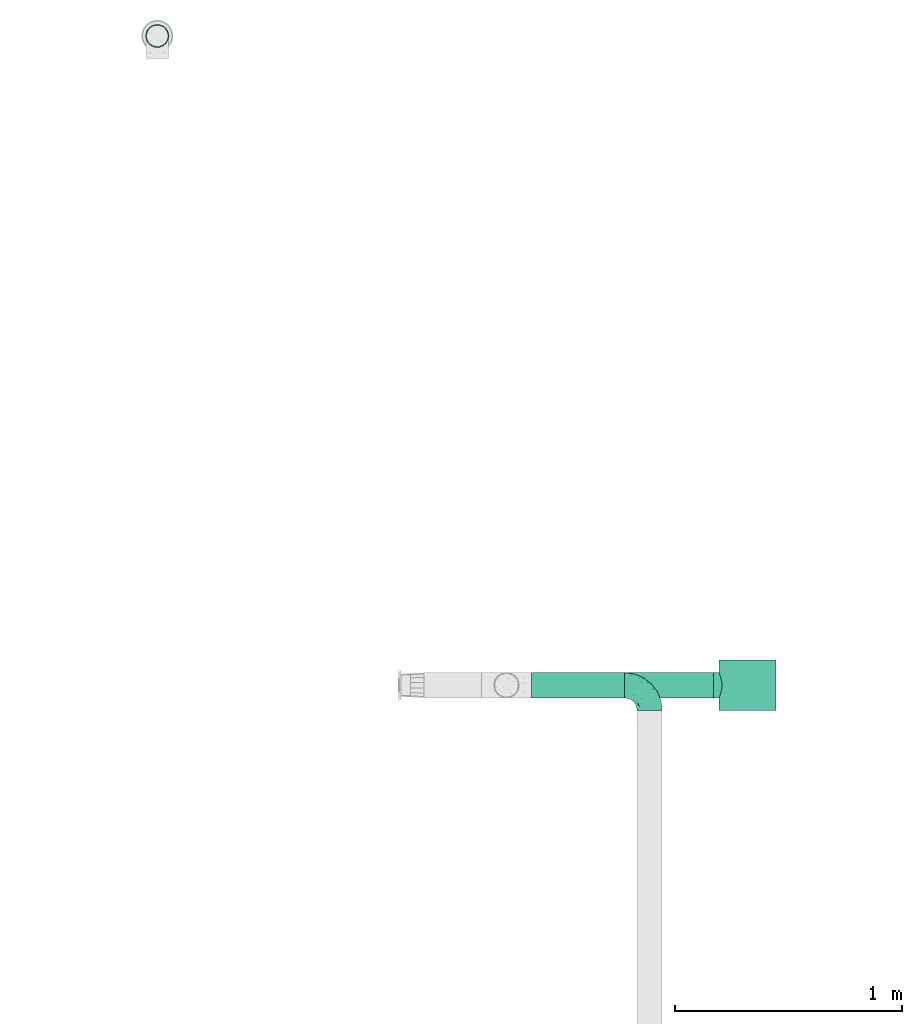
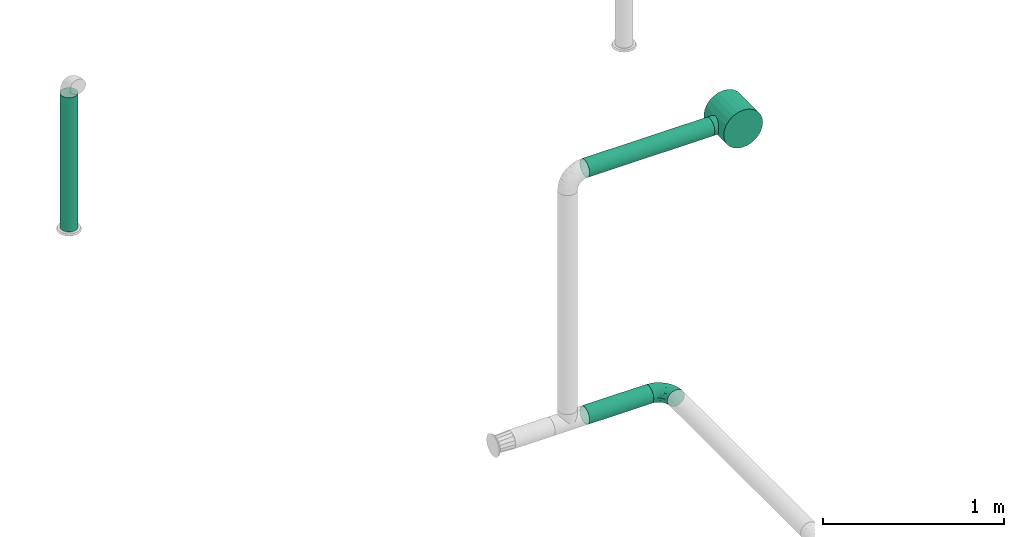
# One storey, part 37 of 103: 3 flow segments, 2 flow fittings.
"""IFC2X3 building model written with IfcOpenShell, lengths in millimetres."""

from ifc_helpers import new_model, entity, si_unit, converted_unit, derived_unit, direction, frame, origin_with_axes, origin_2d_with_axis, place, context, subcontext, project, spatial, hollow_circle, extrude, open_shell, surface_model, source, transform, mapped, material, layer, layer_set, layer_usage, type_object, element, save


model = new_model("IFC2X3")

# Units and contexts
model_context = context("Model", 3, precision=1e-05, world=origin_with_axes(), true_north=direction((0.0, 1.0)))
body_context = subcontext(model_context, "Body", "Model", "MODEL_VIEW")
ifc_project = project(units=[si_unit("AREAUNIT", "SQUARE_METRE"), si_unit("VOLUMEUNIT", "CUBIC_METRE", prefix="DECI"), si_unit("TIMEUNIT", "SECOND"), si_unit("THERMODYNAMICTEMPERATUREUNIT", "DEGREE_CELSIUS"), si_unit("PRESSUREUNIT", "PASCAL"), si_unit("MASSUNIT", "GRAM", prefix="KILO"), si_unit("LENGTHUNIT", "METRE", prefix="MILLI"), si_unit("POWERUNIT", "WATT"), si_unit("ELECTRICCURRENTUNIT", "AMPERE"), si_unit("ELECTRICVOLTAGEUNIT", "VOLT"), derived_unit("VOLUMETRICFLOWRATEUNIT", [(si_unit("VOLUMEUNIT", "CUBIC_METRE", prefix="DECI"), 1), (si_unit("TIMEUNIT", "SECOND"), -1)]), derived_unit("LINEARVELOCITYUNIT", [(si_unit("LENGTHUNIT", "METRE"), 1), (si_unit("TIMEUNIT", "SECOND"), -1)]), derived_unit("MASSDENSITYUNIT", [(si_unit("MASSUNIT", "GRAM", prefix="KILO"), 1), (si_unit("VOLUMEUNIT", "CUBIC_METRE"), -1)]), converted_unit("PLANEANGLEUNIT", "DEGREE", entity("IfcRatioMeasure", 0.01745), si_unit("PLANEANGLEUNIT", "RADIAN"), dimensions=[0, 0, 0, 0, 0, 0, 0])], contexts=[model_context])

# Site, building, storey
site_placement = place(None, origin_with_axes())
site = spatial("IfcSite", under=ifc_project, at=site_placement, CompositionType="ELEMENT")
building_placement = place(site_placement, origin_with_axes())
building = spatial("IfcBuilding", under=site, at=building_placement, Name="mc-building", CompositionType="ELEMENT")
storey_placement = place(building_placement, frame((0.0, 0.0, 5900.0), z_axis=(0.0, 0.0, 1.0), x_axis=(1.0, 0.0, 0.0)))
storey = spatial("IfcBuildingStorey", under=building, at=storey_placement, Name="3. Korrus", CompositionType="ELEMENT", Elevation=5900.0)

# Flow fitting
duct_fitting_type_1 = type_object("IfcDuctFittingType", Name="BU", PredefinedType="BEND")
shared_shape_1 = source(origin_with_axes(), body_context, "Body", "SurfaceModel", [
    surface_model("IfcShellBasedSurfaceModel", [(-110.0, 0.0, -55.0), (-110.0, -14.23505, -53.12592), (-110.0, 14.23505, -53.12592), (-110.0, 53.12592, 14.23505), (-110.0, 27.5, -47.63139), (-110.0, 38.89087, -38.89087), (-110.0, -55.0, 0.0), (-110.0, -53.12592, 14.23505), (-110.0, -38.89087, -38.89087), (-110.0, -27.5, -47.63139), (-110.0, -53.12592, -14.23505), (-110.0, -47.63139, -27.5), (-110.0, -14.23505, 53.12592), (-110.0, 14.23505, 53.12592), (-110.0, 27.5, 47.63139), (-110.0, -47.63139, 27.5), (-110.0, -38.89087, 38.89087), (-110.0, -27.5, 47.63139), (-110.0, 0.0, 55.0), (-110.0, 55.0, 0.0), (-110.0, 53.12592, -14.23505), (-110.0, 47.63139, -27.5), (-110.0, 47.63139, 27.5), (-110.0, 38.89087, 38.89087), (-14.23505, 110.0, -53.12592), (-55.0, 110.0, 0.0), (0.0, 110.0, -55.0), (-27.5, 110.0, -47.63139), (-38.89087, 110.0, -38.89087), (-47.63139, 110.0, -27.5), (38.89087, 110.0, -38.89087), (53.12592, 110.0, 14.23505), (27.5, 110.0, -47.63139), (14.23505, 110.0, -53.12592), (47.63139, 110.0, -27.5), (53.12592, 110.0, -14.23505), (55.0, 110.0, 0.0), (-53.12592, 110.0, -14.23505), (-53.12592, 110.0, 14.23505), (-47.63139, 110.0, 27.5), (-38.89087, 110.0, 38.89087), (-27.5, 110.0, 47.63139), (0.0, 110.0, 55.0), (-14.23505, 110.0, 53.12592), (38.89087, 110.0, 38.89087), (47.63139, 110.0, 27.5), (27.5, 110.0, 47.63139), (14.23505, 110.0, 53.12592), (-64.21732, 48.68956, 43.63444), (-76.6405, 38.18013, 45.55988), (-60.44912, 32.56953, 51.94617), (-76.00813, 5.38378, 55.0), (-90.15553, 11.94394, 54.09138), (-78.5998, 26.77405, 50.81338), (-70.18771, 18.55163, 54.03432), (-75.55424, 54.2118, 32.41257), (-93.27622, 45.77614, 33.48188), (-96.12334, 22.13664, 50.81337), (-21.00813, 45.34362, 55.0), (-18.36258, 70.48427, 54.04484), (-32.04182, 59.64019, 52.24446), (-63.88653, 74.77858, 17.99134), (-74.66383, 63.08407, 19.92123), (-63.60674, 66.07878, 29.97482), (-99.597, 52.72185, 18.52927), (-93.11138, 56.59448, 10.50359), (-98.21577, 57.34403, 0.0), (-53.42855, 92.60092, 21.04759), (-88.54852, 54.8376, 21.04759), (-11.86161, 90.23965, 54.10313), (-5.38378, 76.00813, 55.0), (-57.34403, 98.21577, 0.0), (-56.64619, 93.12774, 10.22088), (-45.34362, 21.00813, 55.0), (-44.60838, 44.60838, 52.13415), (-92.68484, 35.46673, 43.63443), (-22.25266, 95.40765, 50.81337), (-35.97783, 90.61597, 43.63443), (-43.70931, 69.58671, 44.47149), (-27.23711, 77.39884, 50.81337), (-57.2828, 79.3123, 24.9774), (-58.67786, 84.31125, 16.04456), (-82.93277, 60.36161, 12.91784), (-49.88337, 54.51816, 47.224), (-74.57753, 66.83759, 9.55742), (-45.35812, 94.97281, 33.48188), (-59.18663, 88.95241, 0.0), (-51.517, 78.6292, 33.48188), (-65.14788, 80.03077, 0.0), (-56.45322, 62.06476, 39.63545), (-88.95241, 59.18663, 0.0), (-71.10913, 71.10913, 0.0), (-80.03077, 65.14788, 0.0), (-94.9309, 45.36788, -33.48188), (-93.11358, 56.60141, -10.46614), (-99.64997, 52.79499, -18.30015), (-90.20425, 36.08686, -43.63443), (-79.99933, 46.56772, -37.92748), (-76.00813, 5.38378, -55.0), (-72.75364, 19.68651, -53.60527), (-45.34362, 21.00813, -55.0), (-21.91957, 65.12078, -53.85897), (-5.38378, 76.00813, -55.0), (-21.00813, 45.34362, -55.0), (-35.41876, 92.89265, -43.63443), (-91.10309, 11.02766, -54.21832), (-45.77614, 93.27622, -33.48188), (-90.50474, 23.21022, -50.81337), (-70.92854, 33.31794, -49.51754), (-78.52933, 63.35627, -11.73997), (-24.91508, 84.05606, -50.81337), (-88.78941, 54.74452, -21.04759), (-69.59921, 57.34866, -33.48187), (-73.36422, 62.46673, -22.94182), (-63.49062, 67.59111, -28.46929), (-56.59448, 93.11138, -10.50359), (-54.8376, 88.54852, -21.04759), (-54.10679, 75.85581, -32.31867), (-57.75956, 31.09612, -52.80882), (-52.72185, 99.597, -18.52927), (-12.62913, 89.46304, -53.99097), (-34.46825, 66.46123, -50.04329), (-43.9837, 43.9837, -52.42279), (-65.78527, 72.58348, -17.68796), (-70.34468, 43.65295, -44.21951), (-57.47001, 51.99467, -44.91465), (-60.72547, 82.29174, -12.88567), (-42.34915, 74.24548, -43.63444), (-57.25194, 63.5016, -38.08211), (-80.95344, 53.56991, -29.32027), (-52.32891, 4.55257, -54.0482), (32.52942, 47.13398, -30.48571), (14.88266, 20.92917, -33.7947), (14.95561, 36.05775, -42.26543), (30.24048, 70.09027, -41.7461), (19.3559, 65.35825, -48.00507), (-70.35075, -46.44478, -19.5952), (-47.13398, -32.52942, -30.48571), (-28.49299, -30.5778, -16.4009), (-4.55257, 52.32891, -54.0482), (-22.4954, 22.4954, -53.25347), (-75.47368, -11.22546, -52.60718), (-81.32209, -51.5606, -9.98467), (-80.81763, -41.84862, -32.14655), (-70.09027, -30.24048, -41.7461), (-36.05774, -14.95561, -42.26543), (-9.15831, -10.852, -27.8997), (-65.35825, -19.3559, -48.00507), (11.22546, 75.47368, -52.60718), (3.94376, 43.9333, -50.53315), (-13.39742, 13.39743, -48.13058), (-43.9333, -3.94376, -50.53315), (49.37776, 67.29486, 0.0), (41.8609, 47.82256, -9.92641), (50.20582, 74.51695, -9.9731), (18.93131, 11.7156, -17.56239), (-27.5, -32.89419, 0.0), (-1.23348, -12.25375, -12.18106), (41.84862, 80.81763, -32.14655), (35.70604, 41.31408, -20.38235), (46.44478, 70.35075, -19.5952), (32.89419, 27.5, 0.0), (6.67262, -6.67262, 0.0), (-67.29486, -49.37776, 0.0), (-50.36265, -42.95545, -9.51562), (-5.47251, 5.47251, -39.92906), (-70.35075, -46.44478, 19.5952), (-74.51695, -50.20582, 9.9731), (-41.31407, -35.70604, 20.38235), (-47.13398, -32.52942, 30.48571), (-80.81763, -41.84862, 32.14655), (-4.55257, 52.32891, 54.0482), (11.22546, 75.47368, 52.60718), (-43.9333, -3.94376, 50.53315), (-65.35825, -19.3559, 48.00507), (-36.05774, -14.95561, 42.26543), (-70.09027, -30.24048, 41.7461), (-11.7156, -18.93131, 17.56239), (30.5778, 28.49299, 16.4009), (12.25375, 1.23348, 12.18106), (51.5606, 81.32209, 9.98467), (42.95545, 50.36265, 9.51562), (-75.47368, -11.22546, 52.60718), (-52.32891, 4.55257, 54.0482), (3.94376, 43.9333, 50.53315), (-22.4954, 22.4954, 53.25347), (-13.39742, 13.39743, 48.13058), (10.852, 9.15831, 27.8997), (-20.92916, -14.88266, 33.79469), (-47.82256, -41.8609, 9.92641), (32.52942, 47.13398, 30.48571), (46.44478, 70.35075, 19.5952), (41.84862, 80.81763, 32.14655), (30.24048, 70.09027, 41.7461), (19.3559, 65.35825, 48.00507), (14.95561, 36.05775, 42.26543), (-5.47251, 5.47251, 39.92906)], [open_shell([[[0, 1, 2]], [[2, 3, 4]], [[4, 3, 5]], [[2, 6, 7]], [[8, 6, 9]], [[1, 9, 6]], [[10, 6, 11]], [[8, 11, 6]], [[6, 2, 1]], [[12, 13, 14]], [[15, 2, 7]], [[16, 17, 2]], [[2, 17, 12]], [[12, 18, 13]], [[19, 20, 3]], [[5, 3, 21]], [[20, 21, 3]], [[22, 3, 2]], [[23, 22, 2]], [[12, 14, 2]], [[2, 14, 23]], [[15, 16, 2]], [[24, 25, 26]], [[27, 25, 24]], [[25, 28, 29]], [[28, 25, 27]], [[30, 26, 31]], [[26, 30, 32]], [[32, 33, 26]], [[34, 31, 35]], [[31, 34, 30]], [[35, 31, 36]], [[29, 37, 25]], [[38, 39, 26]], [[39, 40, 26]], [[41, 42, 40]], [[42, 26, 40]], [[42, 41, 43]], [[26, 44, 45]], [[31, 26, 45]], [[26, 46, 44]], [[47, 46, 26]], [[42, 47, 26]], [[25, 38, 26]], [[48, 49, 50]], [[18, 51, 52]], [[53, 54, 50]], [[55, 56, 49]], [[56, 22, 23]], [[13, 57, 14]], [[58, 59, 60]], [[61, 62, 63]], [[3, 64, 65]], [[53, 52, 54]], [[3, 65, 66]], [[67, 39, 38]], [[56, 68, 64]], [[65, 64, 68]], [[69, 59, 70]], [[38, 71, 72]], [[73, 58, 74]], [[75, 49, 56]], [[76, 69, 43]], [[53, 57, 52]], [[77, 78, 79]], [[41, 76, 43]], [[43, 69, 42]], [[55, 68, 56]], [[23, 14, 75]], [[76, 77, 79]], [[80, 67, 81]], [[62, 82, 68]], [[60, 78, 83]], [[62, 84, 82]], [[85, 77, 40]], [[81, 67, 72]], [[86, 72, 71]], [[87, 85, 67]], [[61, 81, 88]], [[77, 41, 40]], [[78, 77, 87]], [[23, 75, 56]], [[83, 89, 48]], [[85, 40, 39]], [[62, 68, 55]], [[89, 87, 63]], [[83, 48, 50]], [[57, 75, 14]], [[49, 75, 53]], [[67, 85, 39]], [[87, 77, 85]], [[63, 62, 55]], [[89, 55, 48]], [[80, 63, 87]], [[66, 65, 90]], [[66, 19, 3]], [[84, 91, 92]], [[92, 90, 82]], [[65, 82, 90]], [[61, 84, 62]], [[92, 82, 84]], [[68, 82, 65]], [[3, 22, 64]], [[56, 64, 22]], [[38, 25, 71]], [[81, 72, 86]], [[38, 72, 67]], [[91, 61, 88]], [[80, 81, 61]], [[63, 80, 61]], [[67, 80, 87]], [[77, 76, 41]], [[79, 59, 69]], [[79, 69, 76]], [[42, 69, 70]], [[60, 59, 79]], [[58, 70, 59]], [[78, 60, 79]], [[58, 60, 74]], [[52, 57, 13]], [[75, 57, 53]], [[18, 52, 13]], [[52, 51, 54]], [[51, 73, 54]], [[50, 73, 74]], [[73, 50, 54]], [[50, 74, 83]], [[60, 83, 74]], [[89, 83, 78]], [[87, 89, 78]], [[55, 89, 63]], [[50, 49, 53]], [[55, 49, 48]], [[81, 86, 88]], [[91, 84, 61]], [[5, 21, 93]], [[90, 94, 66]], [[20, 94, 95]], [[96, 93, 97]], [[98, 99, 100]], [[96, 4, 5]], [[101, 102, 103]], [[28, 27, 104]], [[2, 105, 0]], [[104, 106, 28]], [[99, 105, 107]], [[108, 107, 96]], [[90, 109, 94]], [[107, 2, 4]], [[20, 66, 94]], [[27, 24, 110]], [[109, 111, 94]], [[112, 113, 114]], [[37, 115, 71]], [[116, 106, 117]], [[99, 118, 100]], [[116, 115, 119]], [[37, 119, 115]], [[24, 120, 110]], [[121, 110, 101]], [[119, 106, 116]], [[101, 110, 120]], [[122, 103, 100]], [[117, 123, 116]], [[124, 125, 108]], [[115, 116, 126]], [[106, 29, 28]], [[26, 102, 120]], [[127, 104, 110]], [[97, 124, 96]], [[125, 122, 118]], [[128, 127, 125]], [[96, 5, 93]], [[115, 126, 86]], [[117, 106, 127]], [[111, 113, 129]], [[95, 93, 21]], [[97, 129, 112]], [[110, 104, 27]], [[106, 104, 127]], [[96, 107, 4]], [[99, 107, 108]], [[99, 108, 118]], [[105, 99, 98]], [[112, 114, 128]], [[121, 125, 127]], [[20, 19, 66]], [[109, 90, 92]], [[94, 111, 95]], [[91, 123, 109]], [[129, 113, 112]], [[93, 95, 111]], [[21, 20, 95]], [[71, 115, 86]], [[71, 25, 37]], [[123, 91, 88]], [[126, 116, 123]], [[123, 88, 126]], [[86, 126, 88]], [[37, 29, 119]], [[106, 119, 29]], [[129, 93, 111]], [[124, 112, 125]], [[0, 105, 98]], [[107, 105, 2]], [[125, 118, 108]], [[100, 118, 122]], [[93, 129, 97]], [[113, 111, 109]], [[109, 123, 113]], [[114, 123, 117]], [[123, 114, 113]], [[128, 114, 117]], [[127, 128, 117]], [[112, 128, 125]], [[103, 122, 101]], [[110, 121, 127]], [[101, 122, 121]], [[125, 121, 122]], [[26, 120, 24]], [[101, 120, 102]], [[96, 124, 108]], [[92, 91, 109]], [[112, 124, 97]], [[100, 130, 98]], [[131, 132, 133]], [[32, 134, 135]], [[136, 137, 138]], [[139, 140, 103]], [[98, 141, 0]], [[142, 10, 136]], [[143, 144, 137]], [[6, 10, 142]], [[137, 145, 146]], [[144, 147, 145]], [[143, 136, 11]], [[11, 136, 10]], [[8, 143, 11]], [[148, 149, 139]], [[8, 9, 144]], [[9, 1, 147]], [[130, 141, 98]], [[103, 140, 100]], [[148, 135, 149]], [[150, 151, 140]], [[152, 153, 154]], [[130, 140, 151]], [[148, 26, 33]], [[147, 1, 141]], [[155, 146, 132]], [[156, 138, 157]], [[134, 30, 158]], [[150, 140, 149]], [[158, 30, 34]], [[30, 134, 32]], [[153, 159, 160]], [[131, 160, 159]], [[144, 145, 137]], [[36, 152, 154]], [[146, 138, 137]], [[155, 161, 162]], [[158, 160, 131]], [[133, 149, 135]], [[156, 163, 164]], [[163, 142, 164]], [[139, 103, 102]], [[153, 152, 161]], [[34, 35, 160]], [[162, 157, 155]], [[132, 165, 133]], [[157, 146, 155]], [[140, 130, 100]], [[141, 130, 151]], [[141, 151, 147]], [[141, 1, 0]], [[102, 26, 148]], [[140, 139, 149]], [[102, 148, 139]], [[135, 33, 32]], [[151, 150, 145]], [[9, 147, 144]], [[151, 145, 147]], [[145, 165, 146]], [[135, 148, 33]], [[133, 135, 134]], [[131, 133, 134]], [[133, 165, 150]], [[133, 150, 149]], [[145, 150, 165]], [[132, 131, 159]], [[146, 165, 132]], [[160, 158, 34]], [[134, 158, 131]], [[144, 143, 8]], [[136, 143, 137]], [[155, 153, 161]], [[154, 153, 160]], [[153, 155, 159]], [[132, 159, 155]], [[160, 35, 154]], [[36, 154, 35]], [[164, 136, 138]], [[6, 142, 163]], [[136, 164, 142]], [[156, 164, 138]], [[156, 157, 162]], [[146, 157, 138]], [[15, 7, 166]], [[6, 163, 167]], [[168, 169, 166]], [[166, 169, 170]], [[171, 172, 70]], [[173, 174, 175]], [[17, 176, 174]], [[177, 156, 162]], [[176, 16, 170]], [[170, 16, 15]], [[161, 178, 179]], [[152, 180, 181]], [[182, 173, 183]], [[18, 12, 182]], [[184, 185, 186]], [[183, 185, 73]], [[183, 73, 51]], [[177, 187, 188]], [[189, 168, 166]], [[187, 178, 190]], [[16, 176, 17]], [[161, 152, 181]], [[45, 191, 31]], [[45, 44, 192]], [[192, 191, 45]], [[180, 36, 31]], [[193, 194, 195]], [[46, 47, 194]], [[193, 195, 190]], [[193, 44, 46]], [[172, 42, 70]], [[185, 58, 73]], [[189, 163, 156]], [[163, 189, 167]], [[70, 58, 171]], [[184, 171, 185]], [[169, 188, 175]], [[180, 31, 191]], [[192, 193, 190]], [[191, 190, 178]], [[182, 174, 173]], [[194, 47, 172]], [[190, 195, 187]], [[186, 185, 173]], [[162, 179, 177]], [[188, 196, 175]], [[179, 187, 177]], [[185, 171, 58]], [[172, 171, 184]], [[172, 184, 194]], [[172, 47, 42]], [[51, 18, 182]], [[185, 183, 173]], [[51, 182, 183]], [[174, 12, 17]], [[184, 186, 195]], [[46, 194, 193]], [[184, 195, 194]], [[195, 196, 187]], [[174, 182, 12]], [[175, 174, 176]], [[169, 175, 176]], [[175, 196, 186]], [[175, 186, 173]], [[195, 186, 196]], [[188, 169, 168]], [[187, 196, 188]], [[166, 170, 15]], [[176, 170, 169]], [[193, 192, 44]], [[191, 192, 190]], [[177, 189, 156]], [[167, 189, 166]], [[189, 177, 168]], [[188, 168, 177]], [[166, 7, 167]], [[6, 167, 7]], [[181, 191, 178]], [[36, 180, 152]], [[191, 181, 180]], [[161, 181, 178]], [[161, 179, 162]], [[187, 179, 178]]])]),
])
flow_fitting_1_placement = place(storey_placement, frame((7989.21808, 9877.62755, 2345.0), z_axis=(0.0, 0.0, 1.0), x_axis=(0.0, 1.0, 0.0)))
element("IfcFlowFitting", 1, at=flow_fitting_1_placement, inside=storey, type_object=duct_fitting_type_1, Name="BU", context=body_context, shape_type="MappedRepresentation", body=[
    mapped(shared_shape_1, transform((0.0, 0.0, 0.0), scale=1.0)),
])

# Flow segments
ifc_material = material(Name="FZ1")
ifc_layer = layer(ifc_material, 0.0)
ifc_layer_set = layer_set([ifc_layer], Name="FZ1")
ifc_layer_usage = layer_usage(ifc_layer_set, "AXIS1", "POSITIVE", 0.0)
duct_segment_type = type_object("IfcDuctSegmentType", PredefinedType="RIGIDSEGMENT")
shared_shape_2 = source(origin_with_axes(), body_context, "Body", "SweptSolid", [
    extrude(hollow_circle(Radius=55.0, WallThickness=2.0, at=origin_2d_with_axis()), frame((0.0, 0.0, 0.0), z_axis=(1.0, 0.0, 0.0), x_axis=(0.0, 1.0, 0.0)), (0.0, 0.0, 1.0), 410.1),
])
flow_segment_1_placement = place(storey_placement, frame((7879.21808, 9877.62755, 2345.0), z_axis=(0.0, 0.0, 1.0), x_axis=(-1.0, 0.0, 0.0)))
element("IfcFlowSegment", 2, at=flow_segment_1_placement, inside=storey, type_object=duct_segment_type, material=ifc_layer_usage, context=body_context, shape_type="MappedRepresentation", body=[
    mapped(shared_shape_2, transform((0.0, 0.0, 0.0), scale=1.0)),
])
shared_shape_3 = source(origin_with_axes(), body_context, "Body", "SweptSolid", [
    extrude(hollow_circle(Radius=50.0, WallThickness=2.0, at=origin_2d_with_axis()), frame((0.0, 0.0, 0.0), z_axis=(1.0, 0.0, 0.0), x_axis=(0.0, 1.0, 0.0)), (0.0, 0.0, 1.0), 906.0),
])
flow_segment_2_placement = place(storey_placement, frame((5823.33283, 12733.41275, 2461.97044), z_axis=(1.0, 0.0, 0.0), x_axis=(0.0, 0.0, 1.0)))
element("IfcFlowSegment", 3, at=flow_segment_2_placement, inside=storey, type_object=duct_segment_type, material=ifc_layer_usage, context=body_context, shape_type="MappedRepresentation", body=[
    mapped(shared_shape_3, transform((0.0, 0.0, 0.0), scale=1.0)),
])
shared_shape_4 = source(origin_with_axes(), body_context, "Body", "SweptSolid", [
    extrude(hollow_circle(Radius=55.0, WallThickness=2.0, at=origin_2d_with_axis()), frame((0.0, 0.0, 0.0), z_axis=(1.0, 0.0, 0.0), x_axis=(0.0, 1.0, 0.0)), (0.0, 0.0, 1.0), 799.9),
])
flow_segment_3_placement = place(storey_placement, frame((8269.02679, 9877.62755, 4014.30701), z_axis=(0.0, 0.0, 1.0), x_axis=(-1.0, 0.0, 0.0)))
element("IfcFlowSegment", 4, at=flow_segment_3_placement, inside=storey, type_object=duct_segment_type, material=ifc_layer_usage, context=body_context, shape_type="MappedRepresentation", body=[
    mapped(shared_shape_4, transform((0.0, 0.0, 0.0), scale=1.0)),
])

# Flow fitting
duct_fitting_type_2 = type_object("IfcDuctFittingType", PredefinedType="JUNCTION")
shared_shape_5 = source(origin_with_axes(), body_context, "Body", "SurfaceModel", [
    surface_model("IfcShellBasedSurfaceModel", [(0.0, -150.0, -55.0), (14.23505, -150.0, -53.12592), (-14.23505, -150.0, -53.12592), (-53.12592, -150.0, 14.23505), (-27.5, -150.0, -47.63139), (-47.63139, -150.0, -27.5), (-38.89087, -150.0, -38.89087), (55.0, -150.0, 0.0), (53.12592, -150.0, 14.23505), (38.89087, -150.0, -38.89087), (27.5, -150.0, -47.63139), (53.12592, -150.0, -14.23505), (47.63139, -150.0, -27.5), (-53.12592, -150.0, -14.23505), (-47.63139, -150.0, 27.5), (-38.89087, -150.0, 38.89087), (14.23505, -150.0, 53.12592), (-27.5, -150.0, 47.63139), (-14.23505, -150.0, 53.12592), (47.63139, -150.0, 27.5), (38.89087, -150.0, 38.89087), (27.5, -150.0, 47.63139), (0.0, -150.0, 55.0), (-55.0, -150.0, 0.0), (0.0, -112.24973, 55.0), (-12.37766, -112.9301, 53.58912), (-24.01261, -114.7894, 49.48125), (-34.33641, -117.38394, 42.96523), (-42.94114, -120.18295, 34.36653), (-49.47537, -122.66953, 24.02472), (-53.59142, -124.38666, 12.36769), (-55.0, -125.0, 0.0), (-49.46959, -122.66719, -24.03663), (-42.93393, -120.18037, -34.37554), (-53.588, -124.38519, -12.38248), (-34.32718, -117.38124, -42.9726), (-24.00081, -114.78693, -49.48698), (-12.36238, -112.92842, -53.59265), (0.0, -112.24973, -55.0), (12.37766, -112.9301, -53.58912), (24.01261, -114.7894, -49.48125), (34.33641, -117.38394, -42.96523), (42.94114, -120.18295, -34.36653), (49.47537, -122.66953, -24.02472), (53.59142, -124.38666, -12.36769), (55.0, -125.0, 0.0), (49.47537, -122.66953, 24.02472), (42.94114, -120.18295, 34.36653), (53.59142, -124.38666, 12.36769), (34.33641, -117.38394, 42.96523), (24.01261, -114.7894, 49.48125), (12.37766, -112.9301, 53.58912), (-110.0, 0.0, -125.0), (-110.0, -32.35238, -120.74073), (-110.0, 32.35238, -120.74073), (-110.0, 120.74073, 32.35238), (-110.0, 62.5, -108.25318), (-110.0, 88.38835, -88.38835), (-110.0, 108.25318, -62.5), (-110.0, -125.0, 0.0), (-110.0, -120.74073, 32.35238), (-110.0, -88.38835, -88.38835), (-110.0, -62.5, -108.25318), (-110.0, -120.74073, -32.35238), (-110.0, -108.25318, -62.5), (-110.0, 120.74073, -32.35238), (-110.0, 108.25318, 62.5), (-110.0, 62.5, 108.25318), (-110.0, 32.35238, 120.74073), (-110.0, 88.38835, 88.38835), (-110.0, 0.0, 125.0), (-110.0, -108.25318, 62.5), (-110.0, -88.38835, 88.38835), (-110.0, -32.35238, 120.74073), (-110.0, -62.5, 108.25318), (-110.0, 125.0, 0.0), (110.0, 32.35238, -120.74073), (110.0, 125.0, 0.0), (110.0, 0.0, -125.0), (110.0, 62.5, -108.25318), (110.0, 88.38835, -88.38835), (110.0, 108.25318, -62.5), (110.0, -88.38835, -88.38835), (110.0, -120.74073, 32.35238), (110.0, -62.5, -108.25318), (110.0, -32.35238, -120.74073), (110.0, -108.25318, -62.5), (110.0, -120.74073, -32.35238), (110.0, -125.0, 0.0), (110.0, 120.74073, -32.35238), (110.0, 108.25318, 62.5), (110.0, 120.74073, 32.35238), (110.0, 88.38835, 88.38835), (110.0, 62.5, 108.25318), (110.0, 32.35238, 120.74073), (110.0, -62.5, 108.25318), (110.0, -108.25318, 62.5), (110.0, -88.38835, 88.38835), (110.0, -32.35238, 120.74073), (110.0, 0.0, 125.0), (-110.0, -122.87036, -16.17619), (110.0, -114.49695, -47.42619), (-110.0, -114.49695, -47.42619), (110.0, -122.87036, -16.17619), (110.0, -122.87036, 16.17619), (110.0, -114.49695, 47.42619), (-110.0, -122.87036, 16.17619), (-110.0, -114.49695, 47.42619)], [open_shell([[[0, 1, 2]], [[2, 3, 4]], [[5, 6, 3]], [[6, 4, 3]], [[2, 7, 8]], [[9, 7, 10]], [[1, 10, 7]], [[11, 7, 12]], [[9, 12, 7]], [[7, 2, 1]], [[5, 3, 13]], [[2, 14, 3]], [[2, 15, 14]], [[2, 16, 17]], [[17, 15, 2]], [[16, 18, 17]], [[2, 8, 19]], [[2, 19, 20]], [[2, 20, 21]], [[16, 2, 21]], [[16, 22, 18]], [[23, 13, 3]], [[22, 24, 25]], [[18, 25, 26]], [[22, 25, 18]], [[17, 27, 15]], [[17, 18, 26]], [[27, 17, 26]], [[28, 29, 14]], [[30, 31, 23]], [[29, 30, 3]], [[15, 28, 14]], [[3, 14, 29]], [[23, 3, 30]], [[28, 15, 27]], [[32, 33, 5]], [[34, 32, 13]], [[31, 34, 23]], [[23, 34, 13]], [[32, 5, 13]], [[33, 6, 5]], [[4, 35, 36]], [[36, 37, 2]], [[38, 0, 37]], [[4, 6, 35]], [[2, 4, 36]], [[37, 0, 2]], [[35, 6, 33]], [[0, 38, 39]], [[1, 39, 40]], [[0, 39, 1]], [[10, 41, 9]], [[10, 1, 40]], [[41, 10, 40]], [[42, 43, 12]], [[44, 45, 7]], [[43, 44, 11]], [[9, 42, 12]], [[7, 11, 44]], [[43, 11, 12]], [[42, 9, 41]], [[46, 47, 19]], [[48, 46, 8]], [[45, 48, 7]], [[7, 48, 8]], [[46, 19, 8]], [[47, 20, 19]], [[21, 49, 50]], [[50, 51, 16]], [[24, 22, 51]], [[20, 49, 21]], [[16, 21, 50]], [[22, 16, 51]], [[49, 20, 47]], [[52, 53, 54]], [[54, 55, 56]], [[57, 55, 58]], [[56, 55, 57]], [[54, 59, 60]], [[61, 59, 62]], [[54, 53, 62]], [[63, 59, 64]], [[61, 64, 59]], [[62, 59, 54]], [[65, 58, 55]], [[66, 55, 54]], [[67, 66, 54]], [[67, 54, 68]], [[69, 66, 67]], [[70, 68, 54]], [[60, 71, 54]], [[71, 72, 54]], [[73, 70, 74]], [[72, 74, 70]], [[54, 72, 70]], [[75, 65, 55]], [[76, 77, 78]], [[79, 77, 76]], [[80, 81, 77]], [[80, 77, 79]], [[82, 78, 83]], [[78, 82, 84]], [[84, 85, 78]], [[86, 83, 87]], [[86, 82, 83]], [[88, 87, 83]], [[77, 81, 89]], [[90, 78, 91]], [[78, 90, 92]], [[93, 94, 78]], [[78, 92, 93]], [[95, 78, 94]], [[78, 96, 83]], [[78, 97, 96]], [[94, 98, 95]], [[78, 95, 97]], [[99, 98, 94]], [[78, 77, 91]], [[68, 99, 94]], [[67, 94, 93]], [[70, 99, 68]], [[68, 94, 67]], [[93, 69, 67]], [[93, 92, 69]], [[55, 90, 91]], [[75, 91, 77]], [[92, 66, 69]], [[92, 90, 66]], [[66, 90, 55]], [[91, 75, 55]], [[89, 81, 65]], [[77, 89, 65]], [[65, 75, 77]], [[58, 65, 81]], [[81, 57, 58]], [[81, 80, 57]], [[54, 79, 76]], [[52, 76, 78]], [[80, 56, 57]], [[80, 79, 56]], [[56, 79, 54]], [[76, 52, 54]], [[85, 53, 78]], [[84, 62, 85]], [[82, 86, 38]], [[34, 59, 100]], [[39, 38, 86]], [[40, 101, 41]], [[84, 82, 61]], [[82, 38, 61]], [[85, 62, 53]], [[53, 52, 78]], [[37, 36, 64]], [[33, 102, 35]], [[61, 38, 64]], [[35, 102, 36]], [[61, 62, 84]], [[38, 37, 64]], [[39, 86, 40]], [[101, 42, 41]], [[40, 86, 101]], [[42, 87, 43]], [[88, 45, 44]], [[87, 103, 43]], [[44, 103, 88]], [[43, 103, 44]], [[63, 102, 33]], [[63, 33, 32]], [[102, 64, 36]], [[100, 63, 32]], [[31, 59, 34]], [[100, 32, 34]], [[101, 87, 42]], [[45, 88, 48]], [[104, 83, 46]], [[46, 83, 47]], [[46, 48, 104]], [[47, 83, 105]], [[96, 50, 105]], [[31, 30, 59]], [[59, 30, 106]], [[27, 107, 28]], [[60, 106, 29]], [[60, 29, 28]], [[107, 60, 28]], [[50, 96, 51]], [[50, 49, 105]], [[24, 51, 96]], [[29, 106, 30]], [[95, 98, 73]], [[74, 97, 95]], [[24, 96, 97]], [[70, 98, 99]], [[25, 24, 71]], [[48, 88, 104]], [[71, 107, 26]], [[71, 26, 25]], [[24, 72, 71]], [[26, 107, 27]], [[24, 97, 72]], [[97, 74, 72]], [[73, 74, 95]], [[98, 70, 73]], [[47, 105, 49]]])]),
])
flow_fitting_2_placement = place(storey_placement, frame((8419.02679, 9877.62755, 4014.30701), z_axis=(0.0, 0.0, 1.0), x_axis=(0.0, -1.0, 0.0)))
element("IfcFlowFitting", 5, at=flow_fitting_2_placement, inside=storey, type_object=duct_fitting_type_2, context=body_context, shape_type="MappedRepresentation", body=[
    mapped(shared_shape_5, transform((0.0, 0.0, 0.0), scale=1.0)),
])

save(model, "model.ifc")
